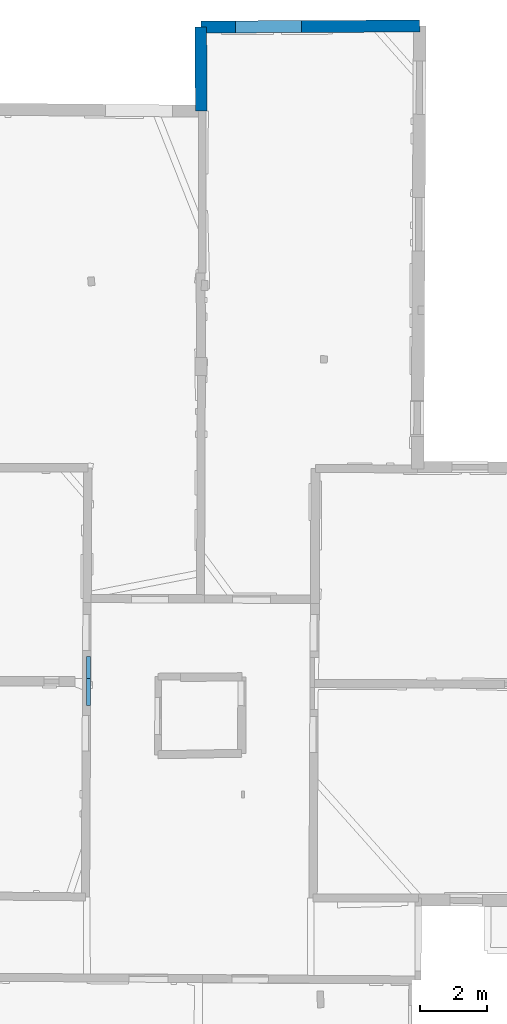
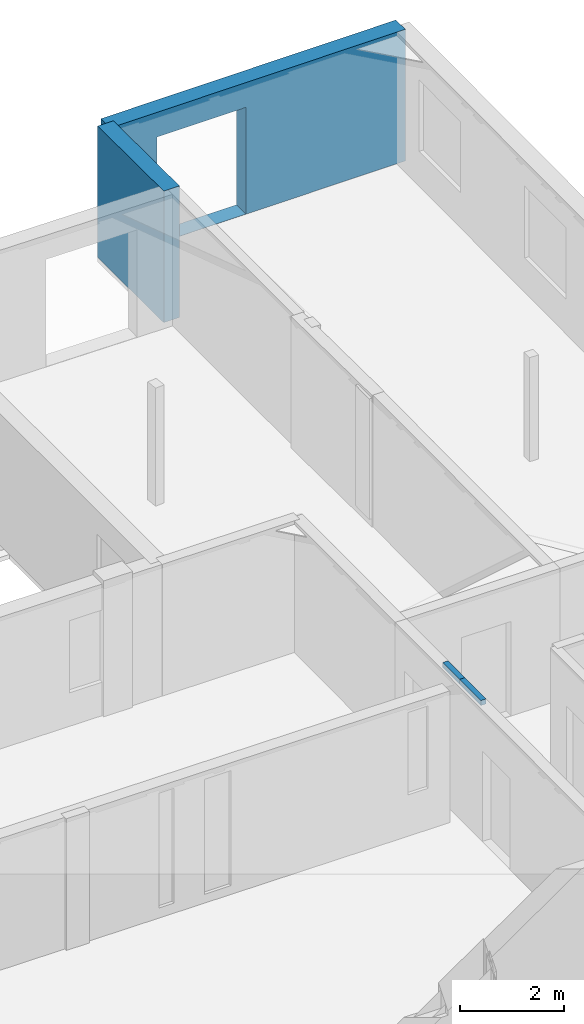
# One storey, part 13 of 17: 4 walls, 1 opening.
"""IFC2X3 building model written with IfcOpenShell, lengths in metres."""

import ifcopenshell
import ifcopenshell.guid

model = None  # the IFC model being written
_history = None  # IfcOwnerHistory: only IFC2X3 demands one
_inside = {}  # id of a spatial element -> (the spatial element, [elements in it])
_under = {}  # id of a project, library or spatial element -> (it, [spatial elements below it])
_declared = {}  # id of a project -> (the project, [libraries it declares])
_typed = {}  # id of a type object -> (the type object, [elements of that type])
_made_of = {}  # id of a material, layer set ... -> (it, [elements and type objects made of it])


def new_model(schema):
    """Start an empty IFC model of exactly this schema.

    Asked for "IFC4X3", IfcOpenShell would pick the latest addendum, in which some entities
    have other attributes; the version numbers below select the first issue.
    IFC2X3 requires an IfcOwnerHistory on every rooted entity: one is made here for all.
    """
    global model, _history
    if schema == "IFC4X3":
        model = ifcopenshell.file(schema_version=(4, 3, 0, 0))
    else:
        model = ifcopenshell.file(schema=schema)
    _inside.clear()
    _under.clear()
    _declared.clear()
    _typed.clear()
    _made_of.clear()
    _history = None
    if model.schema == "IFC2X3":
        org = make("IfcOrganization", Name="unknown")
        user = make(
            "IfcPersonAndOrganization",
            ThePerson=make("IfcPerson", FamilyName="unknown"),
            TheOrganization=org,
        )
        app = make(
            "IfcApplication",
            ApplicationDeveloper=org,
            Version="unknown",
            ApplicationFullName="unknown",
            ApplicationIdentifier="unknown",
        )
        _history = make(
            "IfcOwnerHistory",
            OwningUser=user,
            OwningApplication=app,
            ChangeAction="ADDED",
            CreationDate=0,
        )
    return model


def make(cls, **values):
    """One entity of the class cls with the attributes given. An attribute that is None is left unset."""
    return model.create_entity(
        cls, **{name: value for name, value in values.items() if value is not None}
    )


def entity(cls, *values):
    """Any entity or typed value of the class cls, its attributes in the order of the schema. None: left unset."""
    e = model.create_entity(cls)
    for i, value in enumerate(values):
        if value is not None:
            e[i] = value
    return e


def rooted(cls, **values):
    """An entity with a GlobalId (a new one), such as an element, a storey or a relation."""
    return make(cls, GlobalId=ifcopenshell.guid.new(), OwnerHistory=_history, **values)


def si_unit(unit_type, name, prefix=None):
    """IfcSIUnit, for example si_unit("LENGTHUNIT", "METRE", prefix="MILLI")."""
    return make("IfcSIUnit", UnitType=unit_type, Prefix=prefix, Name=name)


def converted_unit(unit_type, name, factor, base, dimensions=None, offset=None):
    """IfcConversionBasedUnit, such as the inch: factor (a typed value) times the base unit."""
    return make(
        "IfcConversionBasedUnit"
        if offset is None
        else "IfcConversionBasedUnitWithOffset",
        ConversionOffset=offset,
        Dimensions=None
        if dimensions is None
        else entity("IfcDimensionalExponents", *dimensions),
        UnitType=unit_type,
        Name=name,
        ConversionFactor=make(
            "IfcMeasureWithUnit", ValueComponent=factor, UnitComponent=base
        ),
    )


def derived_unit(unit_type, elements):
    """IfcDerivedUnit: a product of units, each with its exponent."""
    return make(
        "IfcDerivedUnit",
        Elements=[
            make("IfcDerivedUnitElement", Unit=unit, Exponent=power)
            for unit, power in elements
        ],
        UnitType=unit_type,
    )


def assignment(units):
    """IfcUnitAssignment: the units of a project."""
    return None if units is None else make("IfcUnitAssignment", Units=units)


def point(xyz):
    """IfcCartesianPoint."""
    return None if xyz is None else make("IfcCartesianPoint", Coordinates=xyz)


def direction(xyz):
    """IfcDirection."""
    return None if xyz is None else make("IfcDirection", DirectionRatios=xyz)


def frame(location, z_axis=None, x_axis=None):
    """IfcAxis2Placement3D, a coordinate frame: its origin and axes. An axis left out is left unset."""
    return make(
        "IfcAxis2Placement3D",
        Location=point(location),
        Axis=direction(z_axis),
        RefDirection=direction(x_axis),
    )


def frame_2d(location, x_axis=None):
    """IfcAxis2Placement2D, a coordinate frame in the plane: its origin and x axis."""
    return make(
        "IfcAxis2Placement2D", Location=point(location), RefDirection=direction(x_axis)
    )


def origin():
    """The frame at (0, 0, 0) with its axes left unset."""
    return frame((0.0, 0.0, 0.0))


def place(relative_to, where):
    """IfcLocalPlacement: puts the frame where relative to a parent placement (None: the world)."""
    return make(
        "IfcLocalPlacement", PlacementRelTo=relative_to, RelativePlacement=where
    )


def context(
    kind, dimensions, precision=None, world=None, true_north=None, identifier=None
):
    """IfcGeometricRepresentationContext, for example the 3D "Model" context."""
    return make(
        "IfcGeometricRepresentationContext",
        ContextIdentifier=identifier,
        ContextType=kind,
        CoordinateSpaceDimension=dimensions,
        Precision=precision,
        WorldCoordinateSystem=world,
        TrueNorth=true_north,
    )


def subcontext(parent, identifier, kind, view, scale=None):
    """IfcGeometricRepresentationSubContext, for example "Body" below "Model"."""
    return make(
        "IfcGeometricRepresentationSubContext",
        ContextIdentifier=identifier,
        ContextType=kind,
        ParentContext=parent,
        TargetScale=scale,
        TargetView=view,
    )


def project(units=None, contexts=None):
    """IfcProject with its units and contexts."""
    return rooted(
        "IfcProject",
        Name="project",
        RepresentationContexts=contexts,
        UnitsInContext=assignment(units),
    )


def spatial(cls, under=None, at=None, **own):
    """A site, building, storey or space (cls), placed at a placement, below another one or the project."""
    s = rooted(cls, ObjectPlacement=at, **own)
    if under is not None:
        _under.setdefault(under.id(), (under, []))[1].append(s)
    return s


def polyline(points):
    """IfcPolyline through the points."""
    return make("IfcPolyline", Points=[point(p) for p in points])


def profile(cls, at=None, kind="AREA", **sizes):
    """A parametric profile (cls). Its sizes go by their IFC names, for example OverallWidth=200.0."""
    return make(cls, ProfileType=kind, Position=at, **sizes)


def rectangle(**sizes):
    """IfcRectangleProfileDef."""
    return profile("IfcRectangleProfileDef", **sizes)


def outline(outer, holes=None, kind="AREA"):
    """IfcArbitraryClosedProfileDef: a profile drawn as a closed curve; with holes, ...WithVoids."""
    if holes is None:
        return make("IfcArbitraryClosedProfileDef", ProfileType=kind, OuterCurve=outer)
    return make(
        "IfcArbitraryProfileDefWithVoids",
        ProfileType=kind,
        OuterCurve=outer,
        InnerCurves=holes,
    )


def extrude(swept, where, along, depth):
    """IfcExtrudedAreaSolid: the profile swept, set in the frame where, extruded along a direction by depth."""
    return make(
        "IfcExtrudedAreaSolid",
        SweptArea=swept,
        Position=where,
        ExtrudedDirection=direction(along),
        Depth=depth,
    )


def clip(a, b, op="DIFFERENCE"):
    """IfcBooleanClippingResult: the solid a cut by the half space b."""
    return make(
        "IfcBooleanClippingResult", Operator=op, FirstOperand=a, SecondOperand=b
    )


def halfspace(plane, agree):
    """IfcHalfSpaceSolid: all space on one side of the plane z = 0 of the frame plane."""
    return make(
        "IfcHalfSpaceSolid",
        BaseSurface=make("IfcPlane", Position=plane),
        AgreementFlag=agree,
    )


def shape(context_of_items, identifier, shape_type, items):
    """IfcShapeRepresentation: the items that make up one representation, for example the "Body"."""
    return make(
        "IfcShapeRepresentation",
        ContextOfItems=context_of_items,
        RepresentationIdentifier=identifier,
        RepresentationType=shape_type,
        Items=items,
    )


def material(Name=None, Category=None):
    """IfcMaterial."""
    return make("IfcMaterial", Name=Name, Category=Category)


def layer(
    of_material, thickness, ventilated=None, Name=None, Category=None, Priority=None
):
    """IfcMaterialLayer: one layer of a wall or slab, of a material (None: an air gap)."""
    return make(
        "IfcMaterialLayer",
        Material=of_material,
        LayerThickness=thickness,
        IsVentilated=ventilated,
        Name=Name,
        Category=Category,
        Priority=Priority,
    )


def layer_set(layers, Name=None):
    """IfcMaterialLayerSet."""
    return make("IfcMaterialLayerSet", MaterialLayers=layers, LayerSetName=Name)


def layer_usage(for_layer_set, set_direction, sense, offset, extent=None):
    """IfcMaterialLayerSetUsage: how a layer set lies in its element."""
    return make(
        "IfcMaterialLayerSetUsage",
        ForLayerSet=for_layer_set,
        LayerSetDirection=set_direction,
        DirectionSense=sense,
        OffsetFromReferenceLine=offset,
        ReferenceExtent=extent,
    )


def made_of(thing, what):
    """Note that an element or type object is made of a material, layer set ...; save() writes the relation."""
    if what is not None:
        _made_of.setdefault(what.id(), (what, []))[1].append(thing)
    return thing


def type_object(cls, material=None, **own):
    """A type object (cls), such as IfcWallType, which elements share."""
    return made_of(rooted(cls, **own), material)


def element(
    cls,
    number,
    at=None,
    inside=None,
    cuts=None,
    type_object=None,
    material=None,
    context=None,
    identifier="Body",
    shape_type=None,
    held_by="IfcProductDefinitionShape",
    body=None,
    shapes=None,
    **own,
):
    """One element of the class cls, such as IfcWall. Its Tag is "e" and its number.

    at: its placement. inside: the storey or other place that contains it. cuts: it is an
    opening in that element (IfcRelVoidsElement). A single representation is given by context,
    identifier, shape_type and body (its items); several are given by shapes. held_by: the class
    of the entity that holds the representations. save() writes the other relations.
    """
    e = rooted(cls, Tag="e%d" % number, ObjectPlacement=at, **own)
    if body is not None:
        shapes = [shape(context, identifier, shape_type, body)]
    if shapes is not None:
        e.Representation = make(held_by, Representations=shapes)
    if inside is not None:
        _inside.setdefault(inside.id(), (inside, []))[1].append(e)
    if cuts is not None:
        rooted(
            "IfcRelVoidsElement", RelatingBuildingElement=cuts, RelatedOpeningElement=e
        )
    if type_object is not None:
        _typed.setdefault(type_object.id(), (type_object, []))[1].append(e)
    return made_of(e, material)


def aggregate(whole, parts):
    """IfcRelAggregates: a whole, such as a stair, and the parts it consists of."""
    return rooted("IfcRelAggregates", RelatingObject=whole, RelatedObjects=parts)


def save(model, path):
    """Write the relations noted so far, then the file.

    IfcRelAggregates (storeys below a building ...), IfcRelContainedInSpatialStructure (elements
    in a storey), IfcRelDefinesByType, IfcRelAssociatesMaterial and IfcRelDeclares: one each for
    every whole, place, type object, material and project.
    """
    for whole, parts in _under.values():
        aggregate(whole, parts)
    for where, things in _inside.values():
        rooted(
            "IfcRelContainedInSpatialStructure",
            RelatedElements=things,
            RelatingStructure=where,
        )
    for kind, things in _typed.values():
        rooted("IfcRelDefinesByType", RelatedObjects=things, RelatingType=kind)
    for what, things in _made_of.values():
        rooted("IfcRelAssociatesMaterial", RelatedObjects=things, RelatingMaterial=what)
    for by, libraries in _declared.values():
        rooted("IfcRelDeclares", RelatingContext=by, RelatedDefinitions=libraries)
    model.write(path)


model = new_model("IFC2X3")

# Units and contexts
model_context = context("Model", 3, precision=1e-05, world=origin(), true_north=direction((0.0, 1.0)))
body_context = subcontext(model_context, "Body", "Model", "MODEL_VIEW")
ifc_project = project(units=[si_unit("LENGTHUNIT", "METRE"), si_unit("AREAUNIT", "SQUARE_METRE"), si_unit("VOLUMEUNIT", "CUBIC_METRE"), converted_unit("PLANEANGLEUNIT", "DEGREE", entity("IfcRatioMeasure", 0.0174532925199433), si_unit("PLANEANGLEUNIT", "RADIAN"), dimensions=[0, 0, 0, 0, 0, 0, 0]), si_unit("MASSUNIT", "GRAM", prefix="KILO"), derived_unit("MASSDENSITYUNIT", [(si_unit("MASSUNIT", "GRAM", prefix="KILO"), 1), (si_unit("LENGTHUNIT", "METRE"), -3)]), derived_unit("MOMENTOFINERTIAUNIT", [(si_unit("LENGTHUNIT", "METRE"), 4)]), si_unit("TIMEUNIT", "SECOND"), si_unit("FREQUENCYUNIT", "HERTZ"), si_unit("THERMODYNAMICTEMPERATUREUNIT", "DEGREE_CELSIUS"), derived_unit("THERMALTRANSMITTANCEUNIT", [(si_unit("MASSUNIT", "GRAM", prefix="KILO"), 1), (si_unit("THERMODYNAMICTEMPERATUREUNIT", "KELVIN"), -1), (si_unit("TIMEUNIT", "SECOND"), -3)]), derived_unit("VOLUMETRICFLOWRATEUNIT", [(si_unit("LENGTHUNIT", "METRE"), 3), (si_unit("TIMEUNIT", "SECOND"), -1)]), si_unit("ELECTRICCURRENTUNIT", "AMPERE"), si_unit("ELECTRICVOLTAGEUNIT", "VOLT"), si_unit("POWERUNIT", "WATT"), si_unit("FORCEUNIT", "NEWTON", prefix="KILO"), si_unit("ILLUMINANCEUNIT", "LUX"), si_unit("LUMINOUSFLUXUNIT", "LUMEN"), si_unit("LUMINOUSINTENSITYUNIT", "CANDELA"), derived_unit("USERDEFINED", [(si_unit("MASSUNIT", "GRAM", prefix="KILO"), -1), (si_unit("LENGTHUNIT", "METRE"), -2), (si_unit("TIMEUNIT", "SECOND"), 3), (si_unit("LUMINOUSFLUXUNIT", "LUMEN"), 1)]), derived_unit("LINEARVELOCITYUNIT", [(si_unit("LENGTHUNIT", "METRE"), 1), (si_unit("TIMEUNIT", "SECOND"), -1)]), si_unit("PRESSUREUNIT", "PASCAL"), derived_unit("USERDEFINED", [(si_unit("LENGTHUNIT", "METRE"), -2), (si_unit("MASSUNIT", "GRAM", prefix="KILO"), 1), (si_unit("TIMEUNIT", "SECOND"), -2)]), derived_unit("LINEARFORCEUNIT", [(si_unit("MASSUNIT", "GRAM", prefix="KILO"), 1), (si_unit("LENGTHUNIT", "METRE"), 1), (si_unit("TIMEUNIT", "SECOND"), -2), (si_unit("LENGTHUNIT", "METRE"), -1)]), derived_unit("PLANARFORCEUNIT", [(si_unit("MASSUNIT", "GRAM", prefix="KILO"), 1), (si_unit("LENGTHUNIT", "METRE"), 1), (si_unit("TIMEUNIT", "SECOND"), -2), (si_unit("LENGTHUNIT", "METRE"), -2)])], contexts=[model_context])

# Site, building, storey
placement_1 = place(None, origin())
site = spatial("IfcSite", under=ifc_project, at=placement_1, CompositionType="ELEMENT")
building = spatial("IfcBuilding", under=site, at=placement_1, CompositionType="ELEMENT")
storey_placement = place(placement_1, frame((0.0, 0.0, 12.0782108306885)))
storey = spatial("IfcBuildingStorey", under=building, at=storey_placement, Name="Level 5", CompositionType="ELEMENT", Elevation=12.0782108306885)

# Walls
ifc_material = material(Name="Default wall")
ifc_layer_1 = layer(ifc_material, 0.349999994039536)
ifc_layer_set_1 = layer_set([ifc_layer_1], Name="wall_thickness_0.3500")
ifc_layer_usage_1 = layer_usage(ifc_layer_set_1, "AXIS2", "POSITIVE", -0.174999997019768)
wall_type_1 = type_object("IfcWallType", Name="wall_thickness_0.3500", PredefinedType="STANDARD", material=ifc_layer_set_1)
wall_1_placement = place(storey_placement, frame((6.38904572475638, 77.3226540187234, 0.0), z_axis=(0.0, 0.0, 1.0), x_axis=(0.00374549436125152, -0.999992985611394, 0.0)))
element("IfcWallStandardCase", 1, at=wall_1_placement, inside=storey, type_object=wall_type_1, material=ifc_layer_usage_1, Name="Wall:349", ObjectType="Wall", context=body_context, shape_type="Clipping", body=[
    clip(extrude(outline(polyline([(2.52505738458531, -0.174999997019768), (2.52505738458531, 0.174999997019768), (0.0, 0.174999997019768), (0.0, -0.174999997019768), (2.52505738458531, -0.174999997019768)])), origin(), (0.0, 0.0, 1.0), 3.09134044647217), halfspace(frame((-1.16887043985445, 7.21077317187452, 5.77343483799827), z_axis=(-0.395635638206727, 0.00132691330345539, 0.918406598997329), x_axis=(-0.0033538545752215, -0.999994375813928, 0.0)), False)),
])
ifc_layer_2 = layer(ifc_material, 0.119999997317791)
ifc_layer_set_2 = layer_set([ifc_layer_2], Name="wall_thickness_0.1200")
ifc_layer_usage_2 = layer_usage(ifc_layer_set_2, "AXIS2", "POSITIVE", -0.0599999986588955)
wall_type_2 = type_object("IfcWallType", Name="wall_thickness_0.1200", PredefinedType="STANDARD", material=ifc_layer_set_2)
placement_2 = place(placement_1, frame((0.0, 0.0, 15.0509996414185)))
wall_2_placement = place(placement_2, frame((3.023629798501, 58.4233686200276, 0.0), z_axis=(0.0, 0.0, 1.0), x_axis=(-0.00231802283868162, -0.999997313381451, 0.0)))
element("IfcWallStandardCase", 2, at=wall_2_placement, inside=storey, type_object=wall_type_2, material=ifc_layer_usage_2, Name="Wall:236", ObjectType="Wall", context=body_context, shape_type="Clipping", body=[
    clip(clip(extrude(outline(polyline([(0.653844682656643, -0.0599999986588955), (0.653844682656643, 0.0599999986588955), (0.0, 0.0599999986588955), (0.0, -0.0599999986588955), (0.653844682656643, -0.0599999986588955)])), origin(), (0.0, 0.0, 1.0), 0.118551635742188), halfspace(frame((0.870718542981051, 21.6051841864608, 6.04071467173579), z_axis=(-0.389452019792115, 0.00157043229896632, 0.921045415830423), x_axis=(-0.00583205203320549, -0.999982703890235, -0.000760979274747706)), False)), halfspace(frame((-17.4104519396176, -4.32680006091135, 2.8229443740727), z_axis=(-0.000510632876856511, -0.389900439399789, 0.920856876289642), x_axis=(0.00341245659038995, 0.920849691100208, 0.389902810378011)), False)),
])
placement_3 = place(placement_1, frame((0.0, 0.0, 15.0509996414185)))
wall_3_placement = place(placement_3, frame((3.02211417159365, 57.7695256940022, 0.0), z_axis=(0.0, 0.0, 1.0), x_axis=(-0.00231778951763522, -0.999997313922268, 0.0)))
element("IfcWallStandardCase", 3, at=wall_3_placement, inside=storey, type_object=wall_type_2, material=ifc_layer_usage_2, Name="Wall:237", ObjectType="Wall", context=body_context, shape_type="Clipping", body=[
    clip(clip(extrude(outline(polyline([(0.820551215294816, -0.0599999986588955), (0.820551215294816, 0.0599999986588955), (0.0, 0.0599999986588955), (0.0, -0.0599999986588955), (0.820551215294816, -0.0599999986588955)])), origin(), (0.0, 0.0, 1.0), 0.118551635742188), halfspace(frame((-0.00113850478334433, -15.7753291975963, 6.04469779166987), z_axis=(0.391118391414594, -0.00298149403906592, 0.920335544565435), x_axis=(0.00583222948761107, 0.999982702860554, 0.000760972341273259)), False)), halfspace(frame((-18.06429763181, -4.32679584611932, 2.8229443740727), z_axis=(-0.000510723849079357, -0.389900439280637, 0.920856876289642), x_axis=(0.00341267144458012, 0.920849690303982, 0.389902810378011)), False)),
])

# Wall, opening
ifc_layer_3 = layer(ifc_material, 0.360000014305115)
ifc_layer_set_3 = layer_set([ifc_layer_3], Name="wall_thickness_0.3600")
ifc_layer_usage_3 = layer_usage(ifc_layer_set_3, "AXIS2", "POSITIVE", -0.180000007152557)
wall_type_3 = type_object("IfcWallType", Name="wall_thickness_0.3600", PredefinedType="STANDARD", material=ifc_layer_set_3)
wall_4_placement = place(storey_placement, frame((6.38904518381744, 77.322664587762, 0.0), z_axis=(0.0, 0.0, 1.0), x_axis=(0.999989236982379, 0.00463960336651385, 0.0)))
wall_4 = element("IfcWallStandardCase", 4, at=wall_4_placement, inside=storey, type_object=wall_type_3, material=ifc_layer_usage_3, Name="Wall:330", ObjectType="Wall", context=body_context, shape_type="Clipping", body=[
    clip(extrude(outline(polyline([(6.57104888898783, -0.180000007152557), (6.57104888898783, 0.180000007152557), (0.0, 0.180000007152557), (0.0, -0.180000007152557), (6.57104888898783, -0.180000007152557)])), origin(), (0.0, 0.0, 1.0), 3.09134044647217), halfspace(frame((7.21181588813036, 1.16241212794884, 5.77343483799827), z_axis=(0.00168065723361195, 0.395634293646825, 0.918406598997329), x_axis=(-0.99999097735606, 0.00424796498003447, 0.0)), False)),
])
opening_placement = place(wall_4_placement, frame((1.03834580663787, -0.180000007152557, 0.00578975677490234)))
element("IfcOpeningElement", 5, at=opening_placement, cuts=wall_4, Name="Opening : 1980 x 2505 : 279", ObjectType="Opening", context=body_context, shape_type="SweptSolid", body=[
    extrude(rectangle(XDim=1.98, YDim=2.505, at=frame_2d((1.2525, 0.99), x_axis=(0.0, 1.0))), frame((0.0, 0.0, 0.0), z_axis=(0.0, 1.0, 0.0), x_axis=(0.0, 0.0, 1.0)), (0.0, 0.0, 1.0), 0.360000014305115),
])

save(model, "model.ifc")
